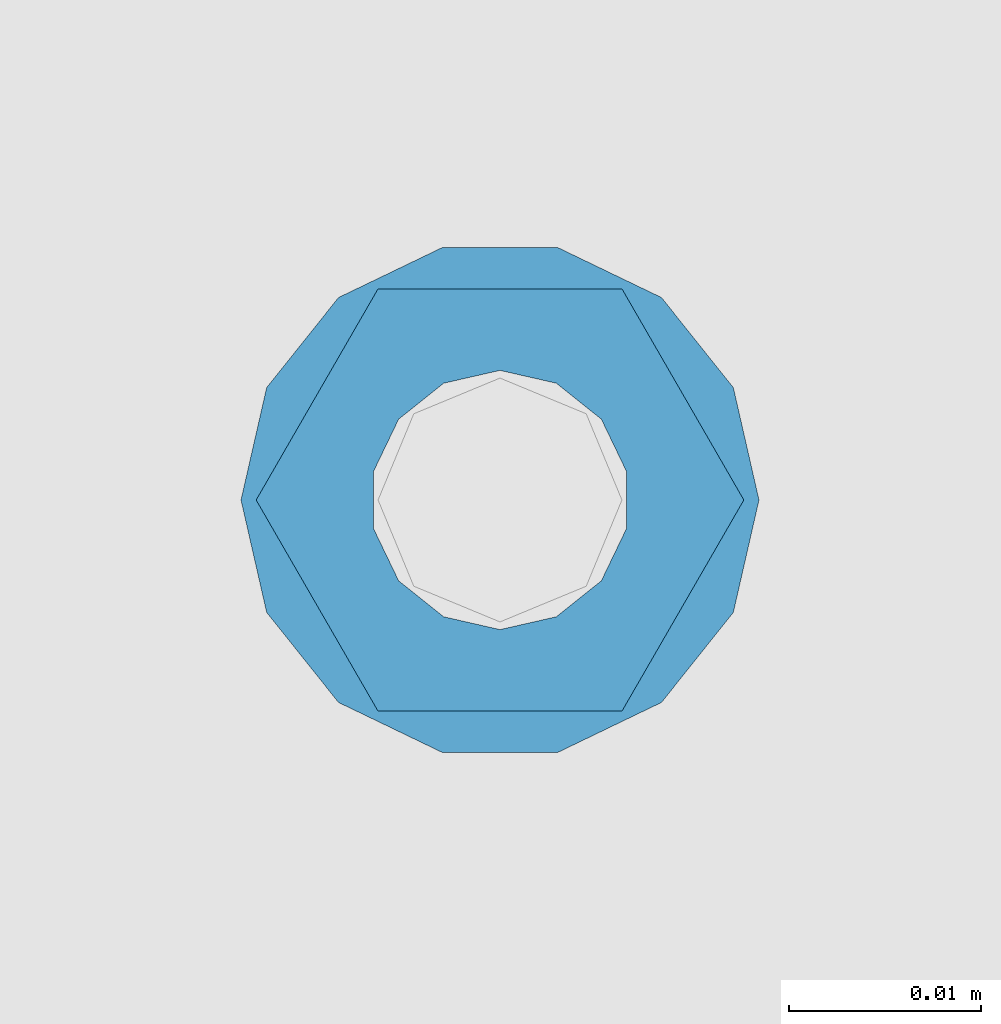
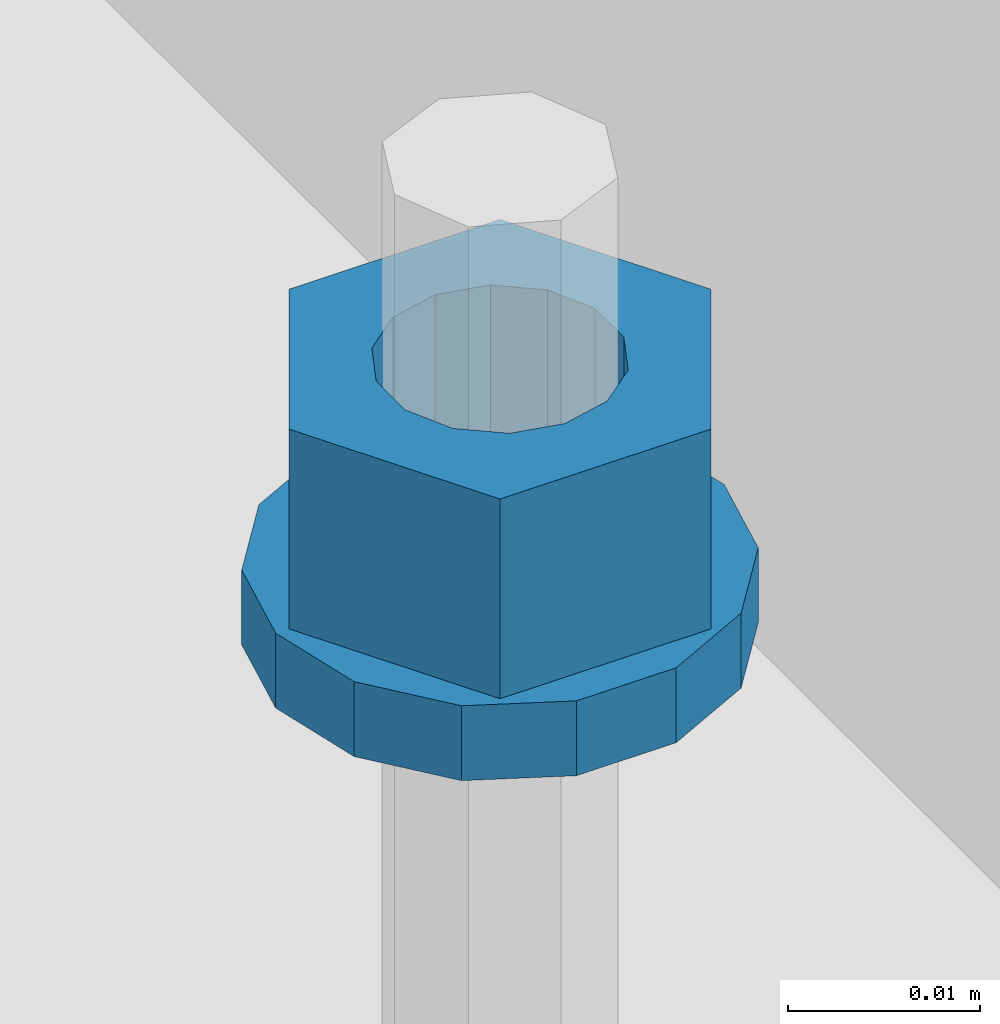
# One storey, part 647 of 1179: 2 columns, 1 element without a shape of its own.
"""IFC2X3 building model written with IfcOpenShell, lengths in millimetres."""

from ifc_helpers import new_model, si_unit, frame, origin_with_axes, place, context, subcontext, project, spatial, faceted_brep, material, type_object, element, aggregate, save


model = new_model("IFC2X3")

# Units and contexts
model_context = context("Model", 3, precision=1e-05, world=origin_with_axes())
body_context = subcontext(model_context, "Body", "Model", "MODEL_VIEW")
ifc_project = project(units=[si_unit("LENGTHUNIT", "METRE", prefix="MILLI"), si_unit("AREAUNIT", "SQUARE_METRE"), si_unit("VOLUMEUNIT", "CUBIC_METRE"), si_unit("MASSUNIT", "GRAM", prefix="KILO"), si_unit("TIMEUNIT", "SECOND"), si_unit("PLANEANGLEUNIT", "RADIAN"), si_unit("SOLIDANGLEUNIT", "STERADIAN"), si_unit("THERMODYNAMICTEMPERATUREUNIT", "DEGREE_CELSIUS"), si_unit("LUMINOUSINTENSITYUNIT", "LUMEN")], contexts=[model_context])

# Site, building, storey
site_placement = place(None, origin_with_axes())
site = spatial("IfcSite", under=ifc_project, at=site_placement, CompositionType="ELEMENT")
building_placement = place(site_placement, origin_with_axes())
building = spatial("IfcBuilding", under=site, at=building_placement, Name="Undefined", CompositionType="ELEMENT")
storey_placement = place(building_placement, origin_with_axes())
storey = spatial("IfcBuildingStorey", under=building, at=storey_placement, Name="Undefined", CompositionType="ELEMENT", Elevation=0.0)

# Assembly, columns
assembly_placement = place(storey_placement, origin_with_axes())
assembly = element("IfcElementAssembly", 1, at=assembly_placement, inside=storey, Name="BEAM", AssemblyPlace="NOTDEFINED", PredefinedType="RIGID_FRAME")
ifc_material = material(Name="STEEL/A307")
column_type_1 = type_object("IfcColumnType", Name="1/2_WASHER", PredefinedType="NOTDEFINED")
column_1_placement = place(assembly_placement, frame((101.600000006011, 40287.5749988592, 4235.45), z_axis=(0.0, 1.0, 0.0), x_axis=(0.0, 0.0, 1.0)))
column_1 = element("IfcColumn", 2, at=column_1_placement, type_object=column_type_1, material=ifc_material, Name="WASHER", ObjectType="1/2_WASHER", context=body_context, shape_type="Brep", body=[
    faceted_brep([(0.0, -13.4899997711182, 0.0), (0.0, -12.1540698217868, -5.85309154138758), (4.76249999999891, -12.1540698217868, -5.85309154138758), (4.76249999999891, -13.4899997711182, 0.0), (0.0, -8.41087728436833, -10.5469065195466), (4.76249999999891, -8.41087728436833, -10.5469065195466), (0.0, -3.00180734814057, -13.1517773121896), (4.76249999999891, -3.00180734814057, -13.1517773121896), (0.0, 3.00180734814057, -13.1517773121896), (4.76249999999891, 3.00180734814057, -13.1517773121896), (0.0, 8.41087728436833, -10.5469065195466), (4.76249999999891, 8.41087728436833, -10.5469065195466), (0.0, 12.1540698217868, -5.85309154138758), (4.76249999999891, 12.1540698217868, -5.85309154138758), (0.0, 13.4899997711182, 0.0), (4.76249999999891, 13.4899997711182, 0.0), (0.0, 12.1540698217868, 5.85309154138758), (4.76249999999891, 12.1540698217868, 5.85309154138758), (0.0, 8.41087728436833, 10.5469065195466), (4.76249999999891, 8.41087728436833, 10.5469065195466), (0.0, 3.00180734814057, 13.1517773121896), (4.76249999999891, 3.00180734814057, 13.1517773121896), (0.0, -3.00180734814057, 13.1517773121896), (4.76249999999891, -3.00180734814057, 13.1517773121896), (0.0, -8.41087728436833, 10.5469065195466), (4.76249999999891, -8.41087728436833, 10.5469065195466), (0.0, -12.1540698217868, 5.85309154138758), (4.76249999999891, -12.1540698217868, 5.85309154138758), (0.0, 0.0, 6.75), (0.0, 2.9287152390425, 6.08153985834178), (4.76249999999891, 2.9287152390425, 6.08153985834178), (4.76249999999891, 0.0, 6.75), (0.0, 5.27736250665839, 4.2085561625463), (4.76249999999891, 5.27736250665839, 4.2085561625463), (0.0, 6.58076340722619, 1.50201630420543), (4.76249999999891, 6.58076340722619, 1.50201630420543), (0.0, 6.58076340722619, -1.50201630420543), (4.76249999999891, 6.58076340722619, -1.50201630420543), (0.0, 5.27736250665839, -4.2085561625463), (4.76249999999891, 5.27736250665839, -4.2085561625463), (0.0, 2.9287152390425, -6.08153985834088), (4.76249999999891, 2.9287152390425, -6.08153985834088), (0.0, 0.0, -6.75), (4.76249999999891, 0.0, -6.75), (0.0, -2.9287152390425, -6.08153985834178), (4.76249999999891, -2.9287152390425, -6.08153985834178), (0.0, -5.27736250665839, -4.2085561625463), (4.76249999999891, -5.27736250665839, -4.2085561625463), (0.0, -6.58076340722619, -1.50201630420543), (4.76249999999891, -6.58076340722619, -1.50201630420543), (0.0, -6.58076340722619, 1.50201630420543), (4.76249999999891, -6.58076340722619, 1.50201630420543), (0.0, -5.27736250665839, 4.2085561625463), (4.76249999999891, -5.27736250665839, 4.2085561625463), (0.0, -2.9287152390425, 6.08153985834088), (4.76249999999891, -2.9287152390425, 6.08153985834088)], [[[0, 1, 2, 3]], [[1, 4, 5, 2]], [[4, 6, 7, 5]], [[6, 8, 9, 7]], [[8, 10, 11, 9]], [[10, 12, 13, 11]], [[12, 14, 15, 13]], [[14, 16, 17, 15]], [[16, 18, 19, 17]], [[18, 20, 21, 19]], [[20, 22, 23, 21]], [[22, 24, 25, 23]], [[24, 26, 27, 25]], [[26, 0, 3, 27]], [[28, 29, 30, 31]], [[29, 32, 33, 30]], [[32, 34, 35, 33]], [[34, 36, 37, 35]], [[36, 38, 39, 37]], [[38, 40, 41, 39]], [[40, 42, 43, 41]], [[42, 44, 45, 43]], [[44, 46, 47, 45]], [[46, 48, 49, 47]], [[48, 50, 51, 49]], [[50, 52, 53, 51]], [[52, 54, 55, 53]], [[54, 28, 31, 55]], [[5, 7, 9, 11, 13, 15, 17, 19, 21, 23, 25, 27, 3, 2], [33, 35, 37, 39, 41, 43, 45, 47, 49, 51, 53, 55, 31, 30]], [[26, 24, 22, 20, 18, 16, 14, 12, 10, 8, 6, 4, 1, 0], [54, 52, 50, 48, 46, 44, 42, 40, 38, 36, 34, 32, 29, 28]]]),
])
column_type_2 = type_object("IfcColumnType", Name="1/2_HEAVY_HEX_NUT", PredefinedType="NOTDEFINED")
column_2_placement = place(assembly_placement, frame((101.600000006011, 40287.5749988592, 4240.2125), z_axis=(0.0, 1.0, 0.0), x_axis=(0.0, 0.0, 1.0)))
column_2 = element("IfcColumn", 3, at=column_2_placement, type_object=column_type_2, material=ifc_material, Name="NUT", ObjectType="1/2_HEAVY_HEX_NUT", context=body_context, shape_type="Brep", body=[
    faceted_brep([(0.0, -12.7, 0.0), (0.0, -6.34999990463257, -11.0), (12.7000000000007, -6.34999990463257, -11.0), (12.7000000000007, -12.6999998092651, 0.0), (0.0, 6.34999990463257, -11.0), (12.7000000000007, 6.34999990463257, -11.0), (0.0, 12.7, 0.0), (12.7000000000007, 12.6999998092651, 0.0), (0.0, 6.34999990463257, 11.0), (12.7000000000007, 6.34999990463257, 11.0), (0.0, -6.34999990463257, 11.0), (12.7000000000007, -6.34999990463257, 11.0), (0.0, 0.0, 6.75), (0.0, 2.9287152390425, 6.08153985834178), (12.7000000000007, 2.9287152390425, 6.08153985834178), (12.7000000000007, 0.0, 6.75), (0.0, 5.27736250665839, 4.2085561625463), (12.7000000000007, 5.27736250665839, 4.2085561625463), (0.0, 6.58076340722619, 1.50201630420543), (12.7000000000007, 6.58076340722619, 1.50201630420543), (0.0, 6.58076340722619, -1.50201630420543), (12.7000000000007, 6.58076340722619, -1.50201630420543), (0.0, 5.27736250665839, -4.2085561625463), (12.7000000000007, 5.27736250665839, -4.2085561625463), (0.0, 2.9287152390425, -6.08153985834088), (12.7000000000007, 2.9287152390425, -6.08153985834088), (0.0, 0.0, -6.75), (12.7000000000007, 0.0, -6.75), (0.0, -2.9287152390425, -6.08153985834178), (12.7000000000007, -2.9287152390425, -6.08153985834178), (0.0, -5.27736250665839, -4.2085561625463), (12.7000000000007, -5.27736250665839, -4.2085561625463), (0.0, -6.58076340722619, -1.50201630420543), (12.7000000000007, -6.58076340722619, -1.50201630420543), (0.0, -6.58076340722619, 1.50201630420543), (12.7000000000007, -6.58076340722619, 1.50201630420543), (0.0, -5.27736250665839, 4.2085561625463), (12.7000000000007, -5.27736250665839, 4.2085561625463), (0.0, -2.9287152390425, 6.08153985834088), (12.7000000000007, -2.9287152390425, 6.08153985834088)], [[[0, 1, 2, 3]], [[1, 4, 5, 2]], [[4, 6, 7, 5]], [[6, 8, 9, 7]], [[8, 10, 11, 9]], [[10, 0, 3, 11]], [[12, 13, 14, 15]], [[13, 16, 17, 14]], [[16, 18, 19, 17]], [[18, 20, 21, 19]], [[20, 22, 23, 21]], [[22, 24, 25, 23]], [[24, 26, 27, 25]], [[26, 28, 29, 27]], [[28, 30, 31, 29]], [[30, 32, 33, 31]], [[32, 34, 35, 33]], [[34, 36, 37, 35]], [[36, 38, 39, 37]], [[38, 12, 15, 39]], [[5, 7, 9, 11, 3, 2], [17, 19, 21, 23, 25, 27, 29, 31, 33, 35, 37, 39, 15, 14]], [[10, 8, 6, 4, 1, 0], [38, 36, 34, 32, 30, 28, 26, 24, 22, 20, 18, 16, 13, 12]]]),
])
aggregate(assembly, [column_1, column_2])

save(model, "model.ifc")
